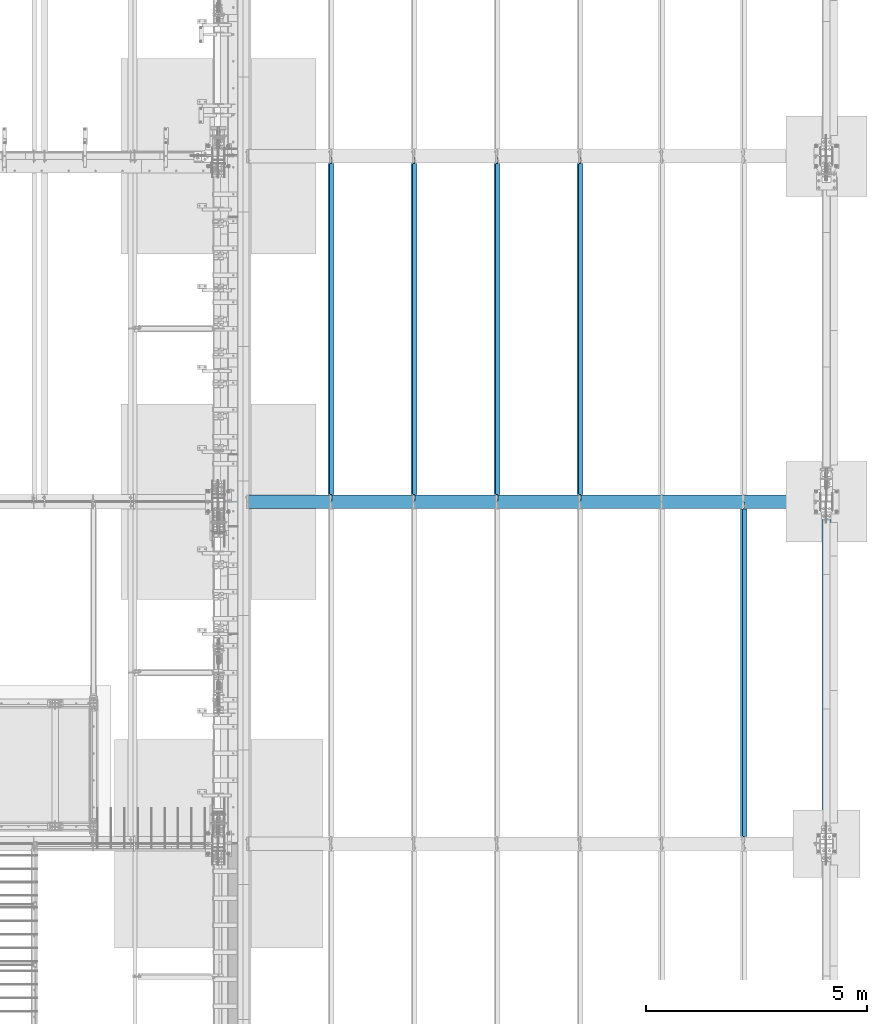
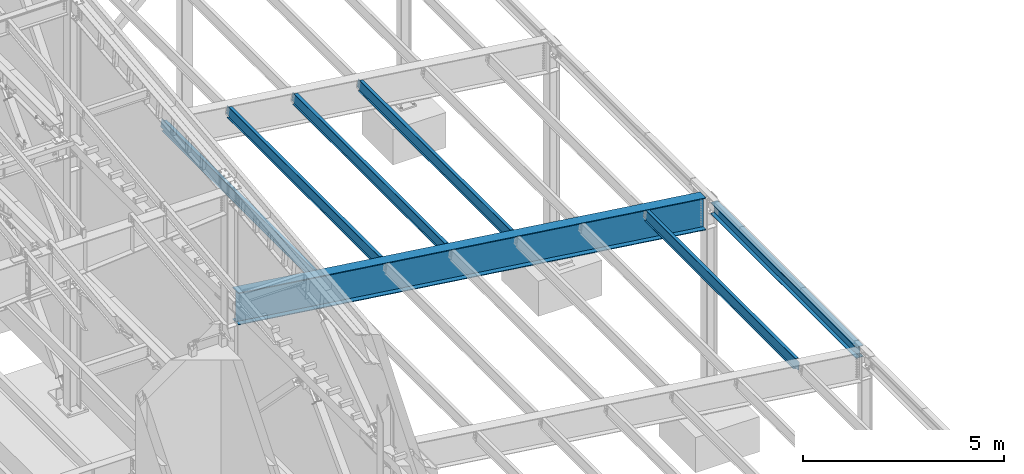
# One storey, part 749 of 1179: 7 beams, 7 elements without a shape of their own.
"""IFC2X3 building model written with IfcOpenShell, lengths in millimetres."""

import ifcopenshell
import ifcopenshell.guid

model = None  # the IFC model being written
_history = None  # IfcOwnerHistory: only IFC2X3 demands one
_inside = {}  # id of a spatial element -> (the spatial element, [elements in it])
_under = {}  # id of a project, library or spatial element -> (it, [spatial elements below it])
_declared = {}  # id of a project -> (the project, [libraries it declares])
_typed = {}  # id of a type object -> (the type object, [elements of that type])
_made_of = {}  # id of a material, layer set ... -> (it, [elements and type objects made of it])


def new_model(schema):
    """Start an empty IFC model of exactly this schema.

    Asked for "IFC4X3", IfcOpenShell would pick the latest addendum, in which some entities
    have other attributes; the version numbers below select the first issue.
    IFC2X3 requires an IfcOwnerHistory on every rooted entity: one is made here for all.
    """
    global model, _history
    if schema == "IFC4X3":
        model = ifcopenshell.file(schema_version=(4, 3, 0, 0))
    else:
        model = ifcopenshell.file(schema=schema)
    _inside.clear()
    _under.clear()
    _declared.clear()
    _typed.clear()
    _made_of.clear()
    _history = None
    if model.schema == "IFC2X3":
        org = make("IfcOrganization", Name="unknown")
        user = make(
            "IfcPersonAndOrganization",
            ThePerson=make("IfcPerson", FamilyName="unknown"),
            TheOrganization=org,
        )
        app = make(
            "IfcApplication",
            ApplicationDeveloper=org,
            Version="unknown",
            ApplicationFullName="unknown",
            ApplicationIdentifier="unknown",
        )
        _history = make(
            "IfcOwnerHistory",
            OwningUser=user,
            OwningApplication=app,
            ChangeAction="ADDED",
            CreationDate=0,
        )
    return model


def make(cls, **values):
    """One entity of the class cls with the attributes given. An attribute that is None is left unset."""
    return model.create_entity(
        cls, **{name: value for name, value in values.items() if value is not None}
    )


def rooted(cls, **values):
    """An entity with a GlobalId (a new one), such as an element, a storey or a relation."""
    return make(cls, GlobalId=ifcopenshell.guid.new(), OwnerHistory=_history, **values)


def si_unit(unit_type, name, prefix=None):
    """IfcSIUnit, for example si_unit("LENGTHUNIT", "METRE", prefix="MILLI")."""
    return make("IfcSIUnit", UnitType=unit_type, Prefix=prefix, Name=name)


def assignment(units):
    """IfcUnitAssignment: the units of a project."""
    return None if units is None else make("IfcUnitAssignment", Units=units)


def point(xyz):
    """IfcCartesianPoint."""
    return None if xyz is None else make("IfcCartesianPoint", Coordinates=xyz)


def direction(xyz):
    """IfcDirection."""
    return None if xyz is None else make("IfcDirection", DirectionRatios=xyz)


def frame(location, z_axis=None, x_axis=None):
    """IfcAxis2Placement3D, a coordinate frame: its origin and axes. An axis left out is left unset."""
    return make(
        "IfcAxis2Placement3D",
        Location=point(location),
        Axis=direction(z_axis),
        RefDirection=direction(x_axis),
    )


def origin_with_axes():
    """The frame at (0, 0, 0) with the z axis (0, 0, 1) and the x axis (1, 0, 0) written out."""
    return frame((0.0, 0.0, 0.0), z_axis=(0.0, 0.0, 1.0), x_axis=(1.0, 0.0, 0.0))


def place(relative_to, where):
    """IfcLocalPlacement: puts the frame where relative to a parent placement (None: the world)."""
    return make(
        "IfcLocalPlacement", PlacementRelTo=relative_to, RelativePlacement=where
    )


def context(
    kind, dimensions, precision=None, world=None, true_north=None, identifier=None
):
    """IfcGeometricRepresentationContext, for example the 3D "Model" context."""
    return make(
        "IfcGeometricRepresentationContext",
        ContextIdentifier=identifier,
        ContextType=kind,
        CoordinateSpaceDimension=dimensions,
        Precision=precision,
        WorldCoordinateSystem=world,
        TrueNorth=true_north,
    )


def subcontext(parent, identifier, kind, view, scale=None):
    """IfcGeometricRepresentationSubContext, for example "Body" below "Model"."""
    return make(
        "IfcGeometricRepresentationSubContext",
        ContextIdentifier=identifier,
        ContextType=kind,
        ParentContext=parent,
        TargetScale=scale,
        TargetView=view,
    )


def project(units=None, contexts=None):
    """IfcProject with its units and contexts."""
    return rooted(
        "IfcProject",
        Name="project",
        RepresentationContexts=contexts,
        UnitsInContext=assignment(units),
    )


def spatial(cls, under=None, at=None, **own):
    """A site, building, storey or space (cls), placed at a placement, below another one or the project."""
    s = rooted(cls, ObjectPlacement=at, **own)
    if under is not None:
        _under.setdefault(under.id(), (under, []))[1].append(s)
    return s


def faces_of(points, faces, orient=None, outer=None):
    """IfcFace entities. A face is a list of loops; a loop is a list of indices into points, from 0.

    orient and outer hold one flag for each loop. By default every Orientation is true, the
    first loop of a face is its IfcFaceOuterBound and the others are IfcFaceBound.
    """
    made = []
    for i, loops in enumerate(faces):
        bounds = []
        for j, loop in enumerate(loops):
            is_outer = j == 0 if outer is None else outer[i][j]
            bounds.append(
                make(
                    "IfcFaceOuterBound" if is_outer else "IfcFaceBound",
                    Bound=make("IfcPolyLoop", Polygon=[points[k] for k in loop]),
                    Orientation=True if orient is None else orient[i][j],
                )
            )
        made.append(make("IfcFace", Bounds=bounds))
    return made


def faceted_brep(points, faces, orient=None, outer=None, voids=None):
    """IfcFacetedBrep: a solid bounded by flat faces; with voids (closed shells), ...WithVoids."""
    shared = [point(p) for p in points]
    hull = make("IfcClosedShell", CfsFaces=faces_of(shared, faces, orient, outer))
    if voids is None:
        return make("IfcFacetedBrep", Outer=hull)
    return make(
        "IfcFacetedBrepWithVoids",
        Outer=hull,
        Voids=[
            make(cls, CfsFaces=faces_of(shared, fs, o, b)) for cls, fs, o, b in voids
        ],
    )


def shape(context_of_items, identifier, shape_type, items):
    """IfcShapeRepresentation: the items that make up one representation, for example the "Body"."""
    return make(
        "IfcShapeRepresentation",
        ContextOfItems=context_of_items,
        RepresentationIdentifier=identifier,
        RepresentationType=shape_type,
        Items=items,
    )


def material(Name=None, Category=None):
    """IfcMaterial."""
    return make("IfcMaterial", Name=Name, Category=Category)


def made_of(thing, what):
    """Note that an element or type object is made of a material, layer set ...; save() writes the relation."""
    if what is not None:
        _made_of.setdefault(what.id(), (what, []))[1].append(thing)
    return thing


def type_object(cls, material=None, **own):
    """A type object (cls), such as IfcWallType, which elements share."""
    return made_of(rooted(cls, **own), material)


def element(
    cls,
    number,
    at=None,
    inside=None,
    cuts=None,
    type_object=None,
    material=None,
    context=None,
    identifier="Body",
    shape_type=None,
    held_by="IfcProductDefinitionShape",
    body=None,
    shapes=None,
    **own,
):
    """One element of the class cls, such as IfcWall. Its Tag is "e" and its number.

    at: its placement. inside: the storey or other place that contains it. cuts: it is an
    opening in that element (IfcRelVoidsElement). A single representation is given by context,
    identifier, shape_type and body (its items); several are given by shapes. held_by: the class
    of the entity that holds the representations. save() writes the other relations.
    """
    e = rooted(cls, Tag="e%d" % number, ObjectPlacement=at, **own)
    if body is not None:
        shapes = [shape(context, identifier, shape_type, body)]
    if shapes is not None:
        e.Representation = make(held_by, Representations=shapes)
    if inside is not None:
        _inside.setdefault(inside.id(), (inside, []))[1].append(e)
    if cuts is not None:
        rooted(
            "IfcRelVoidsElement", RelatingBuildingElement=cuts, RelatedOpeningElement=e
        )
    if type_object is not None:
        _typed.setdefault(type_object.id(), (type_object, []))[1].append(e)
    return made_of(e, material)


def aggregate(whole, parts):
    """IfcRelAggregates: a whole, such as a stair, and the parts it consists of."""
    return rooted("IfcRelAggregates", RelatingObject=whole, RelatedObjects=parts)


def save(model, path):
    """Write the relations noted so far, then the file.

    IfcRelAggregates (storeys below a building ...), IfcRelContainedInSpatialStructure (elements
    in a storey), IfcRelDefinesByType, IfcRelAssociatesMaterial and IfcRelDeclares: one each for
    every whole, place, type object, material and project.
    """
    for whole, parts in _under.values():
        aggregate(whole, parts)
    for where, things in _inside.values():
        rooted(
            "IfcRelContainedInSpatialStructure",
            RelatedElements=things,
            RelatingStructure=where,
        )
    for kind, things in _typed.values():
        rooted("IfcRelDefinesByType", RelatedObjects=things, RelatingType=kind)
    for what, things in _made_of.values():
        rooted("IfcRelAssociatesMaterial", RelatedObjects=things, RelatingMaterial=what)
    for by, libraries in _declared.values():
        rooted("IfcRelDeclares", RelatingContext=by, RelatedDefinitions=libraries)
    model.write(path)


model = new_model("IFC2X3")

# Units and contexts
model_context = context("Model", 3, precision=1e-05, world=origin_with_axes())
body_context = subcontext(model_context, "Body", "Model", "MODEL_VIEW")
ifc_project = project(units=[si_unit("LENGTHUNIT", "METRE", prefix="MILLI"), si_unit("AREAUNIT", "SQUARE_METRE"), si_unit("VOLUMEUNIT", "CUBIC_METRE"), si_unit("MASSUNIT", "GRAM", prefix="KILO"), si_unit("TIMEUNIT", "SECOND"), si_unit("PLANEANGLEUNIT", "RADIAN"), si_unit("SOLIDANGLEUNIT", "STERADIAN"), si_unit("THERMODYNAMICTEMPERATUREUNIT", "DEGREE_CELSIUS"), si_unit("LUMINOUSINTENSITYUNIT", "LUMEN")], contexts=[model_context])

# Site, building, storey
site_placement = place(None, origin_with_axes())
site = spatial("IfcSite", under=ifc_project, at=site_placement, CompositionType="ELEMENT")
building_placement = place(site_placement, origin_with_axes())
building = spatial("IfcBuilding", under=site, at=building_placement, Name="Undefined", CompositionType="ELEMENT")
storey_placement = place(building_placement, origin_with_axes())
storey = spatial("IfcBuildingStorey", under=building, at=storey_placement, Name="Undefined", CompositionType="ELEMENT", Elevation=0.0)

# Assembly, beam
assembly_1_placement = place(storey_placement, origin_with_axes())
assembly_1 = element("IfcElementAssembly", 1, at=assembly_1_placement, inside=storey, Name="BEAM", AssemblyPlace="NOTDEFINED", PredefinedType="RIGID_FRAME")
ifc_material = material(Name="STEEL/A992")
beam_type_1 = type_object("IfcBeamType", Name="W12X22", PredefinedType="NOTDEFINED")
beam_1_placement = place(assembly_1_placement, frame((36199.5820076457, 11480.8, 6273.93066708106), z_axis=(0.133813223953133, 0.0, 0.991006569652931), x_axis=(0.0, 1.0, 0.0)))
beam_1 = element("IfcBeam", 2, at=beam_1_placement, type_object=beam_type_1, material=ifc_material, Name="BEAM", ObjectType="W12X22", context=body_context, shape_type="Brep", body=[
    faceted_brep([(7585.075, -3.17499999982829, -144.462500000047), (7585.075, -50.7999999998428, -144.46250000006), (7585.075, -50.7999999998356, -155.575000000064), (7585.075, 50.8000000001921, -155.575000000037), (7585.075, 50.8000000001775, -144.462500000032), (7585.075, 3.17500000017026, -144.462500000047), (7585.075, 3.17500000016298, -136.524999801413), (7585.075, -3.17499999984284, -136.52499980141), (7586.04172992259, 3.17500000014843, -131.664920283363), (7586.04172992259, -3.17499999984284, -131.66492028336), (7588.79474382307, 3.17500000014843, -127.544743815206), (7588.79474382307, -3.17499999985012, -127.544743815202), (7592.91492029122, 3.17500000014843, -124.791729914725), (7592.91492029122, -3.17499999985012, -124.791729914721), (7597.77499980927, 3.17500000014115, -123.824999992135), (7597.77499980927, -3.17499999985739, -123.824999992132), (7726.3625, -3.17499999985739, -123.824999992028), (7726.3625, 3.17500000014115, -123.824999992019), (165.100000000002, 3.17499999982829, 144.462500000052), (165.100000000002, 50.7999999998356, 144.462500000065), (7585.075, 50.7999999998356, 144.462500000065), (7585.075, 3.17499999982829, 144.462500000052), (165.100000000002, -3.17499999984284, -136.524999799762), (165.100000000002, 3.17500000016298, -136.524999799765), (165.100000000002, 3.17500000017026, -144.462500000047), (165.100000000002, 50.8000000001775, -144.462500000032), (165.100000000002, 50.8000000001921, -155.575000000037), (165.100000000002, -50.7999999998356, -155.575000000064), (165.100000000002, -50.7999999998428, -144.46250000006), (165.100000000002, -3.17499999982829, -144.462500000047), (164.133270077415, -3.17499999984284, -131.664920281712), (164.133270077415, 3.17500000014843, -131.664920281715), (161.380256176937, -3.17499999985739, -127.544743813552), (161.380256176937, 3.17500000014843, -127.544743813558), (157.260079708783, -3.17499999985739, -124.791729913073), (157.260079708783, 3.17500000014115, -124.791729913077), (152.400000190737, -3.17499999985739, -123.824999990484), (152.400000190737, 3.17500000014843, -123.824999990487), (20.6375000000044, -3.17499999985739, -123.824999990466), (20.6375000000044, 3.17500000014843, -123.824999990458), (20.6375000000044, -3.17500000014115, 117.475000009781), (20.6375000000044, 3.17499999986467, 117.475000009788), (152.400000190737, -3.17500000014115, 117.475000009763), (152.400000190737, 3.17499999985739, 117.475000009759), (157.260079708783, -3.17500000014115, 118.44172993235), (157.260079708783, 3.17499999986467, 118.441729932347), (161.380256176937, -3.17500000014115, 121.194743832832), (161.380256176937, 3.17499999985739, 121.194743832826), (164.133270077415, -3.17500000014843, 125.314920300991), (164.133270077415, 3.17499999985012, 125.314920300985), (165.100000000002, -3.17500000016298, 130.174999819041), (165.100000000002, 3.17499999984284, 130.174999819037), (165.100000000002, -50.8000000001994, 155.575000000043), (165.100000000002, 50.7999999998283, 155.57500000007), (165.100000000002, -3.17500000017753, 144.462500000051), (165.100000000002, -50.8000000001775, 144.462500000036), (7585.075, -3.17500000017753, 144.462500000051), (7585.075, -50.8000000001775, 144.462500000036), (7585.075, -50.8000000001994, 155.575000000043), (7585.075, 50.7999999998283, 155.57500000007), (7585.075, -3.17500000015571, 130.174999817393), (7585.075, 3.17499999985012, 130.174999817389), (7586.04172992259, -3.17500000015571, 125.314920299345), (7586.04172992259, 3.17499999985012, 125.314920299339), (7588.79474382307, -3.17500000014843, 121.194743831185), (7588.79474382307, 3.17499999985739, 121.194743831182), (7592.91492029122, -3.17500000014115, 118.441729930704), (7592.91492029122, 3.17499999986467, 118.441729930701), (7597.77499980927, -3.17500000014115, 117.475000008117), (7597.77499980927, 3.17499999986467, 117.475000008111), (7726.3625, -3.17500000014115, 117.47500000822), (7726.3625, 3.17499999985739, 117.475000008229)], [[[0, 1, 2, 3, 4, 5, 6, 7]], [[7, 6, 8, 9]], [[9, 8, 10, 11]], [[11, 10, 12, 13]], [[13, 12, 14, 15]], [[16, 15, 14, 17]], [[18, 19, 20, 21]], [[22, 23, 24, 25, 26, 27, 28, 29]], [[30, 31, 23, 22]], [[32, 33, 31, 30]], [[34, 35, 33, 32]], [[36, 37, 35, 34]], [[38, 39, 37, 36]], [[40, 41, 39, 38]], [[42, 43, 41, 40]], [[44, 45, 43, 42]], [[46, 47, 45, 44]], [[48, 49, 47, 46]], [[50, 51, 49, 48]], [[52, 53, 19, 18, 51, 50, 54, 55]], [[55, 54, 56, 57]], [[52, 55, 57, 58]], [[53, 52, 58, 59]], [[19, 53, 59, 20]], [[58, 57, 56, 60, 61, 21, 20, 59]], [[62, 63, 61, 60]], [[64, 65, 63, 62]], [[66, 67, 65, 64]], [[68, 69, 67, 66]], [[70, 71, 69, 68]], [[71, 70, 16, 17]], [[12, 10, 8, 6, 5, 24, 23, 31, 33, 35, 37, 39, 41, 43, 45, 47, 49, 51, 18, 21, 61, 63, 65, 67, 69, 71, 17, 14]], [[25, 24, 5, 4]], [[26, 25, 4, 3]], [[27, 26, 3, 2]], [[28, 27, 2, 1]], [[29, 28, 1, 0]], [[70, 68, 66, 64, 62, 60, 56, 54, 50, 48, 46, 44, 42, 40, 38, 36, 34, 32, 30, 22, 29, 0, 7, 9, 11, 13, 15, 16]]]),
])
aggregate(assembly_1, [beam_1])

assembly_2_placement = place(storey_placement, origin_with_axes())
assembly_2 = element("IfcElementAssembly", 3, at=assembly_2_placement, inside=storey, Name="BEAM", AssemblyPlace="NOTDEFINED", PredefinedType="RIGID_FRAME")
beam_2_placement = place(assembly_2_placement, frame((32491.1820076831, 19227.8, 6774.66696214898), z_axis=(0.133813223953133, 0.0, 0.991006569652931), x_axis=(0.0, 1.0, 0.0)))
beam_2 = element("IfcBeam", 4, at=beam_2_placement, type_object=beam_type_1, material=ifc_material, Name="BEAM", ObjectType="W12X22", context=body_context, shape_type="Brep", body=[
    faceted_brep([(7661.27499999999, -3.17499999982829, -144.462500000049), (7661.27499999999, -50.7999999998501, -144.462500000061), (7661.27499999999, -50.7999999998283, -155.575000000066), (7661.27499999999, 50.8000000001921, -155.575000000039), (7661.27499999999, 50.8000000001775, -144.462500000034), (7661.27499999999, 3.17500000017026, -144.462500000049), (7661.27499999999, 3.17500000016298, -136.524999801411), (7661.27499999999, -3.17499999984284, -136.524999801408), (7662.24172992258, 3.17500000015571, -131.664920283361), (7662.24172992258, -3.17499999984284, -131.664920283358), (7664.99474382306, 3.17500000014843, -127.544743815204), (7664.99474382306, -3.17499999985012, -127.5447438152), (7669.11492029121, 3.17500000015571, -124.791729914723), (7669.11492029121, -3.17499999985012, -124.791729914719), (7673.97499980926, 3.17500000014115, -123.824999992134), (7673.97499980926, -3.17499999985739, -123.82499999213), (7802.5625, -3.17499999985739, -123.824999992026), (7802.5625, 3.17500000014115, -123.824999992017), (161.925000000007, 3.17499999983556, 144.462500000051), (161.925000000007, 50.7999999998428, 144.462500000063), (7661.275, 50.7999999998356, 144.462500000063), (7661.275, 3.17499999982829, 144.462500000051), (161.925000000007, -3.17499999984284, -136.524999799629), (161.925000000007, 3.17500000016298, -136.524999799632), (161.925000000007, 3.17500000017026, -144.462500000049), (161.925000000007, 50.8000000001775, -144.462500000034), (161.925000000007, 50.8000000001994, -155.575000000039), (161.925000000007, -50.7999999998283, -155.575000000066), (161.925000000007, -50.7999999998428, -144.462500000063), (161.925000000007, -3.17499999982101, -144.462500000049), (160.958270077419, -3.17499999984284, -131.664920281577), (160.958270077419, 3.17500000015571, -131.664920281581), (158.205256176941, -3.17499999984284, -127.54474381342), (158.205256176941, 3.17500000014843, -127.544743813425), (154.085079708788, -3.17499999985012, -124.791729912939), (154.085079708788, 3.17500000015571, -124.791729912944), (149.225000190741, -3.17499999985012, -123.824999990349), (149.225000190741, 3.17500000014115, -123.824999990355), (20.6375000000044, -3.17499999985739, -123.824999990466), (20.6375000000044, 3.17500000014843, -123.824999990458), (20.6375000000044, -3.17500000014115, 117.475000009781), (20.6375000000044, 3.17499999986467, 117.475000009788), (149.225000190741, -3.17500000014115, 117.475000009897), (149.225000190741, 3.17499999986467, 117.475000009894), (154.085079708788, -3.17500000014115, 118.441729932485), (154.085079708788, 3.17499999986467, 118.441729932481), (158.205256176941, -3.17500000014843, 121.194743832966), (158.205256176941, 3.17499999985739, 121.194743832963), (160.958270077419, -3.17500000014843, 125.314920301123), (160.958270077419, 3.17499999985739, 125.31492030112), (161.925000000007, -3.17500000014843, 130.174999819174), (161.925000000007, 3.17499999985012, 130.17499981917), (161.925000000007, -50.8000000001994, 155.575000000041), (161.925000000007, 50.7999999998356, 155.575000000066), (161.925000000007, -3.17500000017026, 144.462500000049), (161.925000000007, -50.8000000001775, 144.462500000034), (7661.275, -3.17500000017753, 144.462500000049), (7661.275, -50.8000000001775, 144.462500000034), (7661.275, -50.8000000001994, 155.575000000041), (7661.275, 50.7999999998283, 155.575000000068), (7661.275, -3.17500000016298, 130.174999817395), (7661.275, 3.17499999985012, 130.174999817391), (7662.24172992259, -3.17500000015571, 125.314920299345), (7662.24172992259, 3.17499999985012, 125.314920299341), (7664.99474382306, -3.17500000014843, 121.194743831187), (7664.99474382306, 3.17499999985739, 121.194743831182), (7669.11492029122, -3.17500000014115, 118.441729930706), (7669.11492029122, 3.17499999986467, 118.441729930701), (7673.97499980926, -3.17500000014115, 117.475000008115), (7673.97499980926, 3.17499999986467, 117.475000008111), (7802.5625, -3.17500000014115, 117.47500000822), (7802.5625, 3.17499999985739, 117.475000008229)], [[[0, 1, 2, 3, 4, 5, 6, 7]], [[7, 6, 8, 9]], [[9, 8, 10, 11]], [[11, 10, 12, 13]], [[13, 12, 14, 15]], [[16, 15, 14, 17]], [[18, 19, 20, 21]], [[22, 23, 24, 25, 26, 27, 28, 29]], [[30, 31, 23, 22]], [[32, 33, 31, 30]], [[34, 35, 33, 32]], [[36, 37, 35, 34]], [[38, 39, 37, 36]], [[40, 41, 39, 38]], [[42, 43, 41, 40]], [[44, 45, 43, 42]], [[46, 47, 45, 44]], [[48, 49, 47, 46]], [[50, 51, 49, 48]], [[52, 53, 19, 18, 51, 50, 54, 55]], [[55, 54, 56, 57]], [[52, 55, 57, 58]], [[53, 52, 58, 59]], [[19, 53, 59, 20]], [[58, 57, 56, 60, 61, 21, 20, 59]], [[62, 63, 61, 60]], [[64, 65, 63, 62]], [[66, 67, 65, 64]], [[68, 69, 67, 66]], [[70, 71, 69, 68]], [[71, 70, 16, 17]], [[12, 10, 8, 6, 5, 24, 23, 31, 33, 35, 37, 39, 41, 43, 45, 47, 49, 51, 18, 21, 61, 63, 65, 67, 69, 71, 17, 14]], [[25, 24, 5, 4]], [[26, 25, 4, 3]], [[27, 26, 3, 2]], [[28, 27, 2, 1]], [[29, 28, 1, 0]], [[70, 68, 66, 64, 62, 60, 56, 54, 50, 48, 46, 44, 42, 40, 38, 36, 34, 32, 30, 22, 29, 0, 7, 9, 11, 13, 15, 16]]]),
])
aggregate(assembly_2, [beam_2])

assembly_3_placement = place(storey_placement, origin_with_axes())
assembly_3 = element("IfcElementAssembly", 5, at=assembly_3_placement, inside=storey, Name="BEAM", AssemblyPlace="NOTDEFINED", PredefinedType="RIGID_FRAME")
beam_3_placement = place(assembly_3_placement, frame((30611.5820076832, 19227.8, 7028.4648111669), z_axis=(0.133813223953133, 0.0, 0.991006569652931), x_axis=(0.0, 1.0, 0.0)))
beam_3 = element("IfcBeam", 6, at=beam_3_placement, type_object=beam_type_1, material=ifc_material, Name="BEAM", ObjectType="W12X22", context=body_context, shape_type="Brep", body=[
    faceted_brep([(7661.27499999999, -3.17499999982829, -144.462500000049), (7661.27499999999, -50.7999999998501, -144.462500000061), (7661.27499999999, -50.7999999998283, -155.575000000066), (7661.27499999999, 50.8000000001921, -155.575000000039), (7661.27499999999, 50.8000000001775, -144.462500000034), (7661.27499999999, 3.17500000017026, -144.462500000049), (7661.27499999999, 3.17500000016298, -136.524999801411), (7661.27499999999, -3.17499999984284, -136.524999801408), (7662.24172992258, 3.17500000015571, -131.664920283361), (7662.24172992258, -3.17499999984284, -131.664920283358), (7664.99474382306, 3.17500000014843, -127.544743815204), (7664.99474382306, -3.17499999985012, -127.5447438152), (7669.11492029121, 3.17500000015571, -124.791729914723), (7669.11492029121, -3.17499999985012, -124.791729914719), (7673.97499980926, 3.17500000014115, -123.824999992134), (7673.97499980926, -3.17499999985739, -123.82499999213), (7802.5625, -3.17499999985739, -123.824999992026), (7802.5625, 3.17500000014115, -123.824999992017), (161.925000000007, 3.17499999983556, 144.462500000051), (161.925000000007, 50.7999999998428, 144.462500000063), (7661.275, 50.7999999998356, 144.462500000063), (7661.275, 3.17499999982829, 144.462500000051), (161.925000000007, -3.17499999984284, -136.524999799629), (161.925000000007, 3.17500000016298, -136.524999799632), (161.925000000007, 3.17500000017026, -144.462500000049), (161.925000000007, 50.8000000001775, -144.462500000034), (161.925000000007, 50.8000000001994, -155.575000000039), (161.925000000007, -50.7999999998283, -155.575000000066), (161.925000000007, -50.7999999998428, -144.462500000063), (161.925000000007, -3.17499999982101, -144.462500000049), (160.958270077419, -3.17499999984284, -131.664920281577), (160.958270077419, 3.17500000015571, -131.664920281581), (158.205256176941, -3.17499999984284, -127.54474381342), (158.205256176941, 3.17500000014843, -127.544743813425), (154.085079708788, -3.17499999985012, -124.791729912939), (154.085079708788, 3.17500000015571, -124.791729912944), (149.225000190741, -3.17499999985012, -123.824999990349), (149.225000190741, 3.17500000014115, -123.824999990355), (20.6375000000044, -3.17499999985739, -123.824999990466), (20.6375000000044, 3.17500000014843, -123.824999990458), (20.6375000000044, -3.17500000014115, 117.475000009781), (20.6375000000044, 3.17499999986467, 117.475000009788), (149.225000190741, -3.17500000014115, 117.475000009897), (149.225000190741, 3.17499999986467, 117.475000009894), (154.085079708788, -3.17500000014115, 118.441729932485), (154.085079708788, 3.17499999986467, 118.441729932481), (158.205256176941, -3.17500000014843, 121.194743832966), (158.205256176941, 3.17499999985739, 121.194743832963), (160.958270077419, -3.17500000014843, 125.314920301123), (160.958270077419, 3.17499999985739, 125.31492030112), (161.925000000007, -3.17500000014843, 130.174999819174), (161.925000000007, 3.17499999985012, 130.17499981917), (161.925000000007, -50.8000000001994, 155.575000000041), (161.925000000007, 50.7999999998356, 155.575000000066), (161.925000000007, -3.17500000017026, 144.462500000049), (161.925000000007, -50.8000000001775, 144.462500000034), (7661.275, -3.17500000017753, 144.462500000049), (7661.275, -50.8000000001775, 144.462500000034), (7661.275, -50.8000000001994, 155.575000000041), (7661.275, 50.7999999998283, 155.575000000068), (7661.275, -3.17500000016298, 130.174999817395), (7661.275, 3.17499999985012, 130.174999817391), (7662.24172992259, -3.17500000015571, 125.314920299345), (7662.24172992259, 3.17499999985012, 125.314920299341), (7664.99474382306, -3.17500000014843, 121.194743831187), (7664.99474382306, 3.17499999985739, 121.194743831182), (7669.11492029122, -3.17500000014115, 118.441729930706), (7669.11492029122, 3.17499999986467, 118.441729930701), (7673.97499980926, -3.17500000014115, 117.475000008115), (7673.97499980926, 3.17499999986467, 117.475000008111), (7802.5625, -3.17500000014115, 117.47500000822), (7802.5625, 3.17499999985739, 117.475000008229)], [[[0, 1, 2, 3, 4, 5, 6, 7]], [[7, 6, 8, 9]], [[9, 8, 10, 11]], [[11, 10, 12, 13]], [[13, 12, 14, 15]], [[16, 15, 14, 17]], [[18, 19, 20, 21]], [[22, 23, 24, 25, 26, 27, 28, 29]], [[30, 31, 23, 22]], [[32, 33, 31, 30]], [[34, 35, 33, 32]], [[36, 37, 35, 34]], [[38, 39, 37, 36]], [[40, 41, 39, 38]], [[42, 43, 41, 40]], [[44, 45, 43, 42]], [[46, 47, 45, 44]], [[48, 49, 47, 46]], [[50, 51, 49, 48]], [[52, 53, 19, 18, 51, 50, 54, 55]], [[55, 54, 56, 57]], [[52, 55, 57, 58]], [[53, 52, 58, 59]], [[19, 53, 59, 20]], [[58, 57, 56, 60, 61, 21, 20, 59]], [[62, 63, 61, 60]], [[64, 65, 63, 62]], [[66, 67, 65, 64]], [[68, 69, 67, 66]], [[70, 71, 69, 68]], [[71, 70, 16, 17]], [[12, 10, 8, 6, 5, 24, 23, 31, 33, 35, 37, 39, 41, 43, 45, 47, 49, 51, 18, 21, 61, 63, 65, 67, 69, 71, 17, 14]], [[25, 24, 5, 4]], [[26, 25, 4, 3]], [[27, 26, 3, 2]], [[28, 27, 2, 1]], [[29, 28, 1, 0]], [[70, 68, 66, 64, 62, 60, 56, 54, 50, 48, 46, 44, 42, 40, 38, 36, 34, 32, 30, 22, 29, 0, 7, 9, 11, 13, 15, 16]]]),
])
aggregate(assembly_3, [beam_3])

assembly_4_placement = place(storey_placement, origin_with_axes())
assembly_4 = element("IfcElementAssembly", 7, at=assembly_4_placement, inside=storey, Name="BEAM", AssemblyPlace="NOTDEFINED", PredefinedType="RIGID_FRAME")
beam_4_placement = place(assembly_4_placement, frame((28731.9820076832, 19227.8, 7282.2626601849), z_axis=(0.133813223953133, 0.0, 0.991006569652931), x_axis=(0.0, 1.0, 0.0)))
beam_4 = element("IfcBeam", 8, at=beam_4_placement, type_object=beam_type_1, material=ifc_material, Name="BEAM", ObjectType="W12X22", context=body_context, shape_type="Brep", body=[
    faceted_brep([(7661.27499999999, -3.17499999982829, -144.462500000049), (7661.27499999999, -50.7999999998501, -144.462500000061), (7661.27499999999, -50.7999999998283, -155.575000000066), (7661.27499999999, 50.8000000001921, -155.575000000039), (7661.27499999999, 50.8000000001775, -144.462500000034), (7661.27499999999, 3.17500000017026, -144.462500000049), (7661.27499999999, 3.17500000016298, -136.524999801411), (7661.27499999999, -3.17499999984284, -136.524999801408), (7662.24172992258, 3.17500000015571, -131.664920283361), (7662.24172992258, -3.17499999984284, -131.664920283358), (7664.99474382306, 3.17500000014843, -127.544743815204), (7664.99474382306, -3.17499999985012, -127.5447438152), (7669.11492029121, 3.17500000015571, -124.791729914723), (7669.11492029121, -3.17499999985012, -124.791729914719), (7673.97499980926, 3.17500000014115, -123.824999992134), (7673.97499980926, -3.17499999985739, -123.82499999213), (7802.5625, -3.17499999985739, -123.824999992026), (7802.5625, 3.17500000014115, -123.824999992017), (161.925000000007, 3.17499999983556, 144.462500000051), (161.925000000007, 50.7999999998428, 144.462500000063), (7661.275, 50.7999999998356, 144.462500000063), (7661.275, 3.17499999982829, 144.462500000051), (161.925000000007, -3.17499999984284, -136.524999799629), (161.925000000007, 3.17500000016298, -136.524999799632), (161.925000000007, 3.17500000017026, -144.462500000049), (161.925000000007, 50.8000000001775, -144.462500000034), (161.925000000007, 50.8000000001994, -155.575000000039), (161.925000000007, -50.7999999998283, -155.575000000066), (161.925000000007, -50.7999999998428, -144.462500000063), (161.925000000007, -3.17499999982101, -144.462500000049), (160.958270077419, -3.17499999984284, -131.664920281577), (160.958270077419, 3.17500000015571, -131.664920281581), (158.205256176941, -3.17499999984284, -127.54474381342), (158.205256176941, 3.17500000014843, -127.544743813425), (154.085079708788, -3.17499999985012, -124.791729912939), (154.085079708788, 3.17500000015571, -124.791729912944), (149.225000190741, -3.17499999985012, -123.824999990349), (149.225000190741, 3.17500000014115, -123.824999990355), (20.6375000000044, -3.17499999985739, -123.824999990466), (20.6375000000044, 3.17500000014843, -123.824999990458), (20.6375000000044, -3.17500000014115, 117.475000009781), (20.6375000000044, 3.17499999986467, 117.475000009788), (149.225000190741, -3.17500000014115, 117.475000009897), (149.225000190741, 3.17499999986467, 117.475000009894), (154.085079708788, -3.17500000014115, 118.441729932485), (154.085079708788, 3.17499999986467, 118.441729932481), (158.205256176941, -3.17500000014843, 121.194743832966), (158.205256176941, 3.17499999985739, 121.194743832963), (160.958270077419, -3.17500000014843, 125.314920301123), (160.958270077419, 3.17499999985739, 125.31492030112), (161.925000000007, -3.17500000014843, 130.174999819174), (161.925000000007, 3.17499999985012, 130.17499981917), (161.925000000007, -50.8000000001994, 155.575000000041), (161.925000000007, 50.7999999998356, 155.575000000066), (161.925000000007, -3.17500000017026, 144.462500000049), (161.925000000007, -50.8000000001775, 144.462500000034), (7661.275, -3.17500000017753, 144.462500000049), (7661.275, -50.8000000001775, 144.462500000034), (7661.275, -50.8000000001994, 155.575000000041), (7661.275, 50.7999999998283, 155.575000000068), (7661.275, -3.17500000016298, 130.174999817395), (7661.275, 3.17499999985012, 130.174999817391), (7662.24172992259, -3.17500000015571, 125.314920299345), (7662.24172992259, 3.17499999985012, 125.314920299341), (7664.99474382306, -3.17500000014843, 121.194743831187), (7664.99474382306, 3.17499999985739, 121.194743831182), (7669.11492029122, -3.17500000014115, 118.441729930706), (7669.11492029122, 3.17499999986467, 118.441729930701), (7673.97499980926, -3.17500000014115, 117.475000008115), (7673.97499980926, 3.17499999986467, 117.475000008111), (7802.5625, -3.17500000014115, 117.47500000822), (7802.5625, 3.17499999985739, 117.475000008229)], [[[0, 1, 2, 3, 4, 5, 6, 7]], [[7, 6, 8, 9]], [[9, 8, 10, 11]], [[11, 10, 12, 13]], [[13, 12, 14, 15]], [[16, 15, 14, 17]], [[18, 19, 20, 21]], [[22, 23, 24, 25, 26, 27, 28, 29]], [[30, 31, 23, 22]], [[32, 33, 31, 30]], [[34, 35, 33, 32]], [[36, 37, 35, 34]], [[38, 39, 37, 36]], [[40, 41, 39, 38]], [[42, 43, 41, 40]], [[44, 45, 43, 42]], [[46, 47, 45, 44]], [[48, 49, 47, 46]], [[50, 51, 49, 48]], [[52, 53, 19, 18, 51, 50, 54, 55]], [[55, 54, 56, 57]], [[52, 55, 57, 58]], [[53, 52, 58, 59]], [[19, 53, 59, 20]], [[58, 57, 56, 60, 61, 21, 20, 59]], [[62, 63, 61, 60]], [[64, 65, 63, 62]], [[66, 67, 65, 64]], [[68, 69, 67, 66]], [[70, 71, 69, 68]], [[71, 70, 16, 17]], [[12, 10, 8, 6, 5, 24, 23, 31, 33, 35, 37, 39, 41, 43, 45, 47, 49, 51, 18, 21, 61, 63, 65, 67, 69, 71, 17, 14]], [[25, 24, 5, 4]], [[26, 25, 4, 3]], [[27, 26, 3, 2]], [[28, 27, 2, 1]], [[29, 28, 1, 0]], [[70, 68, 66, 64, 62, 60, 56, 54, 50, 48, 46, 44, 42, 40, 38, 36, 34, 32, 30, 22, 29, 0, 7, 9, 11, 13, 15, 16]]]),
])
aggregate(assembly_4, [beam_4])

assembly_5_placement = place(storey_placement, origin_with_axes())
assembly_5 = element("IfcElementAssembly", 9, at=assembly_5_placement, inside=storey, Name="BEAM", AssemblyPlace="NOTDEFINED", PredefinedType="RIGID_FRAME")
beam_5_placement = place(assembly_5_placement, frame((26852.3820076832, 19227.8, 7536.06050920288), z_axis=(0.133813223953133, 0.0, 0.991006569652931), x_axis=(0.0, 1.0, 0.0)))
beam_5 = element("IfcBeam", 10, at=beam_5_placement, type_object=beam_type_1, material=ifc_material, Name="BEAM", ObjectType="W12X22", context=body_context, shape_type="Brep", body=[
    faceted_brep([(7661.27499999999, -3.17499999982829, -144.462500000049), (7661.27499999999, -50.7999999998501, -144.462500000061), (7661.27499999999, -50.7999999998283, -155.575000000066), (7661.27499999999, 50.8000000001921, -155.575000000039), (7661.27499999999, 50.8000000001775, -144.462500000034), (7661.27499999999, 3.17500000017026, -144.462500000049), (7661.27499999999, 3.17500000016298, -136.524999801411), (7661.27499999999, -3.17499999984284, -136.524999801408), (7662.24172992258, 3.17500000015571, -131.664920283361), (7662.24172992258, -3.17499999984284, -131.664920283358), (7664.99474382306, 3.17500000014843, -127.544743815204), (7664.99474382306, -3.17499999985012, -127.5447438152), (7669.11492029121, 3.17500000015571, -124.791729914723), (7669.11492029121, -3.17499999985012, -124.791729914719), (7673.97499980926, 3.17500000014115, -123.824999992134), (7673.97499980926, -3.17499999985739, -123.82499999213), (7802.5625, -3.17499999985739, -123.824999992026), (7802.5625, 3.17500000014115, -123.824999992017), (161.925000000007, 3.17499999983556, 144.462500000051), (161.925000000007, 50.7999999998428, 144.462500000063), (7661.275, 50.7999999998356, 144.462500000063), (7661.275, 3.17499999982829, 144.462500000051), (161.925000000007, -3.17499999984284, -136.524999799629), (161.925000000007, 3.17500000016298, -136.524999799632), (161.925000000007, 3.17500000017026, -144.462500000049), (161.925000000007, 50.8000000001775, -144.462500000034), (161.925000000007, 50.8000000001994, -155.575000000039), (161.925000000007, -50.7999999998283, -155.575000000066), (161.925000000007, -50.7999999998428, -144.462500000063), (161.925000000007, -3.17499999982101, -144.462500000049), (160.958270077419, -3.17499999984284, -131.664920281577), (160.958270077419, 3.17500000015571, -131.664920281581), (158.205256176941, -3.17499999984284, -127.54474381342), (158.205256176941, 3.17500000014843, -127.544743813425), (154.085079708788, -3.17499999985012, -124.791729912939), (154.085079708788, 3.17500000015571, -124.791729912944), (149.225000190741, -3.17499999985012, -123.824999990349), (149.225000190741, 3.17500000014115, -123.824999990355), (20.6375000000044, -3.17499999985739, -123.824999990466), (20.6375000000044, 3.17500000014843, -123.824999990458), (20.6375000000044, -3.17500000014115, 117.475000009781), (20.6375000000044, 3.17499999986467, 117.475000009788), (149.225000190741, -3.17500000014115, 117.475000009897), (149.225000190741, 3.17499999986467, 117.475000009894), (154.085079708788, -3.17500000014115, 118.441729932485), (154.085079708788, 3.17499999986467, 118.441729932481), (158.205256176941, -3.17500000014843, 121.194743832966), (158.205256176941, 3.17499999985739, 121.194743832963), (160.958270077419, -3.17500000014843, 125.314920301123), (160.958270077419, 3.17499999985739, 125.31492030112), (161.925000000007, -3.17500000014843, 130.174999819174), (161.925000000007, 3.17499999985012, 130.17499981917), (161.925000000007, -50.8000000001994, 155.575000000041), (161.925000000007, 50.7999999998356, 155.575000000066), (161.925000000007, -3.17500000017026, 144.462500000049), (161.925000000007, -50.8000000001775, 144.462500000034), (7661.275, -3.17500000017753, 144.462500000049), (7661.275, -50.8000000001775, 144.462500000034), (7661.275, -50.8000000001994, 155.575000000041), (7661.275, 50.7999999998283, 155.575000000068), (7661.275, -3.17500000016298, 130.174999817395), (7661.275, 3.17499999985012, 130.174999817391), (7662.24172992259, -3.17500000015571, 125.314920299345), (7662.24172992259, 3.17499999985012, 125.314920299341), (7664.99474382306, -3.17500000014843, 121.194743831187), (7664.99474382306, 3.17499999985739, 121.194743831182), (7669.11492029122, -3.17500000014115, 118.441729930706), (7669.11492029122, 3.17499999986467, 118.441729930701), (7673.97499980926, -3.17500000014115, 117.475000008115), (7673.97499980926, 3.17499999986467, 117.475000008111), (7802.5625, -3.17500000014115, 117.47500000822), (7802.5625, 3.17499999985739, 117.475000008229)], [[[0, 1, 2, 3, 4, 5, 6, 7]], [[7, 6, 8, 9]], [[9, 8, 10, 11]], [[11, 10, 12, 13]], [[13, 12, 14, 15]], [[16, 15, 14, 17]], [[18, 19, 20, 21]], [[22, 23, 24, 25, 26, 27, 28, 29]], [[30, 31, 23, 22]], [[32, 33, 31, 30]], [[34, 35, 33, 32]], [[36, 37, 35, 34]], [[38, 39, 37, 36]], [[40, 41, 39, 38]], [[42, 43, 41, 40]], [[44, 45, 43, 42]], [[46, 47, 45, 44]], [[48, 49, 47, 46]], [[50, 51, 49, 48]], [[52, 53, 19, 18, 51, 50, 54, 55]], [[55, 54, 56, 57]], [[52, 55, 57, 58]], [[53, 52, 58, 59]], [[19, 53, 59, 20]], [[58, 57, 56, 60, 61, 21, 20, 59]], [[62, 63, 61, 60]], [[64, 65, 63, 62]], [[66, 67, 65, 64]], [[68, 69, 67, 66]], [[70, 71, 69, 68]], [[71, 70, 16, 17]], [[12, 10, 8, 6, 5, 24, 23, 31, 33, 35, 37, 39, 41, 43, 45, 47, 49, 51, 18, 21, 61, 63, 65, 67, 69, 71, 17, 14]], [[25, 24, 5, 4]], [[26, 25, 4, 3]], [[27, 26, 3, 2]], [[28, 27, 2, 1]], [[29, 28, 1, 0]], [[70, 68, 66, 64, 62, 60, 56, 54, 50, 48, 46, 44, 42, 40, 38, 36, 34, 32, 30, 22, 29, 0, 7, 9, 11, 13, 15, 16]]]),
])
aggregate(assembly_5, [beam_5])

assembly_6_placement = place(storey_placement, origin_with_axes())
assembly_6 = element("IfcElementAssembly", 11, at=assembly_6_placement, inside=storey, Name="BEAM", AssemblyPlace="NOTDEFINED", PredefinedType="RIGID_FRAME")
beam_type_2 = type_object("IfcBeamType", Name="W40X149", PredefinedType="NOTDEFINED")
beam_6_placement = place(assembly_6_placement, frame((24242.7968808208, 19227.8, 7555.22990684843), z_axis=(0.133813223953133, 0.0, 0.991006569652931), x_axis=(0.99100656965293, 0.0, -0.133813223953134)))
beam_6 = element("IfcBeam", 12, at=beam_6_placement, type_object=beam_type_2, material=ifc_material, Name="BEAM", ObjectType="W40X149", context=body_context, shape_type="Brep", body=[
    faceted_brep([(302.590061503044, -149.224999999999, -485.775000000245), (302.590061503044, 149.224999999999, -485.775000000245), (13853.1182925061, 149.224999999999, -485.775000003989), (13853.1182925061, -149.224999999999, -485.775000003989), (299.803429714837, -149.224999999999, -465.137500000239), (299.803429714837, -7.9375, -465.137500000239), (174.190642954203, -7.9375, 465.137500000114), (174.190642954203, -149.224999999999, 465.137500000114), (171.404011165996, -149.224999999999, 485.77500000012), (171.404011165996, 149.224999999999, 485.77500000012), (174.190642954203, 149.224999999999, 465.137500000114), (174.190642954203, 7.9375, 465.137500000114), (299.803429714837, 7.9375, -465.137500000239), (299.803429714837, 149.224999999999, -465.137500000239), (13850.3316607179, -149.224999999999, -465.137500003979), (13850.3316607179, -7.9375, -465.137500003979), (13724.7188739573, -7.9375, 465.137499996372), (13724.7188739573, -149.224999999999, 465.137499996372), (13721.9322421691, -149.224999999999, 485.774999996378), (13721.9322421691, 149.224999999999, 485.774999996378), (13724.7188739573, 149.224999999999, 465.137499996372), (13724.7188739573, 7.9375, 465.137499996372), (13850.3316607179, 7.9375, -465.137500003979), (13850.3316607179, 149.224999999999, -465.137500003979)], [[[0, 1, 2, 3]], [[0, 4, 5, 6, 7, 8, 9, 10, 11, 12, 13, 1]], [[5, 4, 14, 15]], [[6, 5, 15, 16]], [[7, 6, 16, 17]], [[8, 7, 17, 18]], [[9, 8, 18, 19]], [[10, 9, 19, 20]], [[11, 10, 20, 21]], [[12, 11, 21, 22]], [[13, 12, 22, 23]], [[1, 13, 23, 2]], [[22, 21, 20, 19, 18, 17, 16, 15, 14, 3, 2, 23]], [[4, 0, 3, 14]]]),
])
aggregate(assembly_6, [beam_6])

assembly_7_placement = place(storey_placement, origin_with_axes())
assembly_7 = element("IfcElementAssembly", 13, at=assembly_7_placement, inside=storey, Name="BEAM", AssemblyPlace="NOTDEFINED", PredefinedType="RIGID_FRAME")
beam_type_3 = type_object("IfcBeamType", Name="W14X48", PredefinedType="NOTDEFINED")
beam_7_placement = place(assembly_7_placement, frame((38074.6, 11480.8, 5921.375), z_axis=(0.0, 0.0, 1.0), x_axis=(0.0, 1.0, 0.0)))
beam_7 = element("IfcBeam", 14, at=beam_7_placement, type_object=beam_type_3, material=ifc_material, Name="BEAM", ObjectType="W14X48", context=body_context, shape_type="Brep", body=[
    faceted_brep([(246.0625, -101.599999999999, -174.625), (246.0625, 101.599999999999, -174.625), (7500.93749999999, 101.599999999999, -174.625), (7500.93749999999, -101.599999999999, -174.625), (246.0625, -101.599999999999, -158.75), (246.0625, -3.96875, -158.75), (246.0625, -3.96875, 158.75), (246.0625, -101.599999999999, 158.75), (246.0625, -101.599999999999, 174.625), (246.0625, 101.599999999999, 174.625), (246.0625, 101.599999999999, 158.75), (246.0625, 3.96875, 158.75), (246.0625, 3.96875, 124.565000000086), (246.0625, 3.96875, -105.51499999999), (246.0625, 3.96875, -158.75), (246.0625, 101.599999999999, -158.75), (7500.93749999999, -101.599999999999, -158.75), (7500.93749999999, -3.96875, -158.75), (7500.93749999999, -3.96875, 158.75), (7500.93749999999, -101.599999999999, 158.75), (7500.93749999999, -101.599999999999, 174.625), (7500.93749999999, 101.599999999999, 174.625), (7500.93749999999, 101.599999999999, 158.75), (7500.93749999999, 3.96875, 158.75), (7500.93749999999, 3.96875, 124.565000000086), (7500.93749999999, 3.96875, -105.51499999999), (7500.93749999999, 3.96875, -158.75), (7500.93749999999, 101.599999999999, -158.75)], [[[0, 1, 2, 3]], [[0, 4, 5, 6, 7, 8, 9, 10, 11, 12, 13, 14, 15, 1]], [[5, 4, 16, 17]], [[6, 5, 17, 18]], [[7, 6, 18, 19]], [[8, 7, 19, 20]], [[9, 8, 20, 21]], [[10, 9, 21, 22]], [[11, 10, 22, 23]], [[14, 13, 12, 11, 23, 24, 25, 26]], [[15, 14, 26, 27]], [[1, 15, 27, 2]], [[26, 25, 24, 23, 22, 21, 20, 19, 18, 17, 16, 3, 2, 27]], [[4, 0, 3, 16]]]),
])
aggregate(assembly_7, [beam_7])

save(model, "model.ifc")
